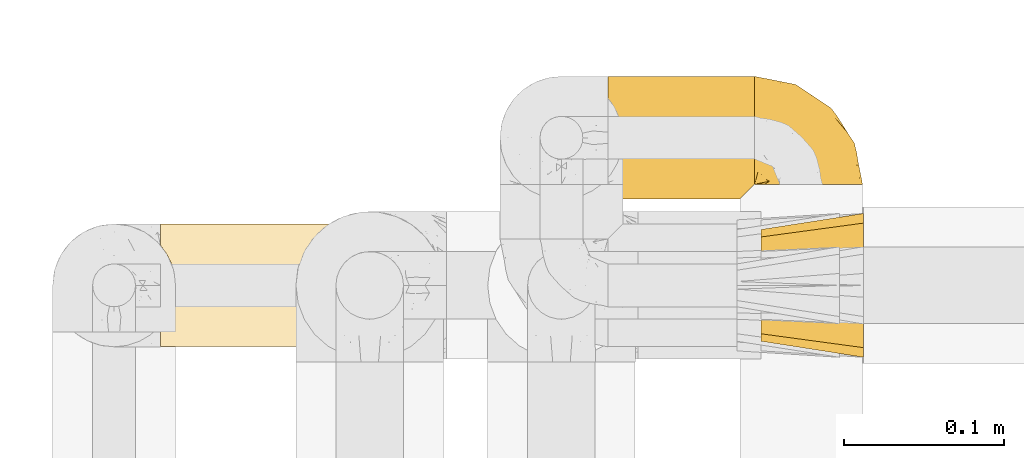
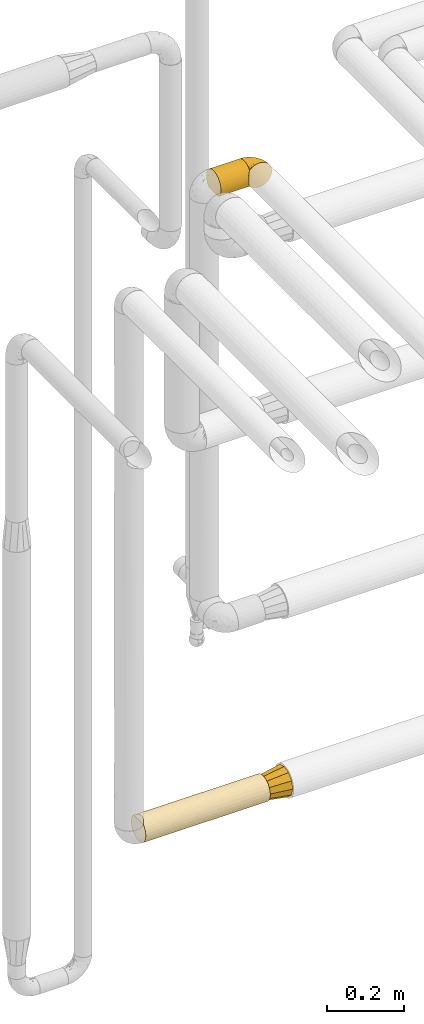
# One storey, part 432 of 827: 4 coverings.
"""IFC2X3 building model written with IfcOpenShell, lengths in millimetres."""

from ifc_helpers import new_model, entity, si_unit, converted_unit, derived_unit, direction, frame, origin, place, context, subcontext, project, spatial, faceted_brep, element, save


model = new_model("IFC2X3")

# Units and contexts
model_context = context("Model", 3, precision=0.01, world=origin(), true_north=direction((6.12303176911189e-17, 1.0)))
body_context = subcontext(model_context, "Body", "Model", "MODEL_VIEW")
ifc_project = project(units=[si_unit("LENGTHUNIT", "METRE", prefix="MILLI"), si_unit("AREAUNIT", "SQUARE_METRE"), si_unit("VOLUMEUNIT", "CUBIC_METRE"), converted_unit("PLANEANGLEUNIT", "DEGREE", entity("IfcRatioMeasure", 0.0174532925199433), si_unit("PLANEANGLEUNIT", "RADIAN"), dimensions=[0, 0, 0, 0, 0, 0, 0]), si_unit("MASSUNIT", "GRAM", prefix="KILO"), derived_unit("MASSDENSITYUNIT", [(si_unit("MASSUNIT", "GRAM", prefix="KILO"), 1), (si_unit("LENGTHUNIT", "METRE"), -3)]), derived_unit("MOMENTOFINERTIAUNIT", [(si_unit("LENGTHUNIT", "METRE"), 4)]), si_unit("TIMEUNIT", "SECOND"), si_unit("FREQUENCYUNIT", "HERTZ"), si_unit("THERMODYNAMICTEMPERATUREUNIT", "DEGREE_CELSIUS"), derived_unit("THERMALTRANSMITTANCEUNIT", [(si_unit("MASSUNIT", "GRAM", prefix="KILO"), 1), (si_unit("THERMODYNAMICTEMPERATUREUNIT", "KELVIN"), -1), (si_unit("TIMEUNIT", "SECOND"), -3)]), derived_unit("VOLUMETRICFLOWRATEUNIT", [(si_unit("LENGTHUNIT", "METRE"), 3), (si_unit("TIMEUNIT", "SECOND"), -1)]), derived_unit("MASSFLOWRATEUNIT", [(si_unit("MASSUNIT", "GRAM", prefix="KILO"), 1), (si_unit("TIMEUNIT", "SECOND"), -1)]), derived_unit("ROTATIONALFREQUENCYUNIT", [(si_unit("TIMEUNIT", "SECOND"), -1)]), si_unit("ELECTRICCURRENTUNIT", "AMPERE"), si_unit("ELECTRICVOLTAGEUNIT", "VOLT"), si_unit("POWERUNIT", "WATT"), si_unit("FORCEUNIT", "NEWTON", prefix="KILO"), si_unit("ILLUMINANCEUNIT", "LUX"), si_unit("LUMINOUSFLUXUNIT", "LUMEN"), si_unit("LUMINOUSINTENSITYUNIT", "CANDELA"), derived_unit("USERDEFINED", [(si_unit("MASSUNIT", "GRAM", prefix="KILO"), -1), (si_unit("LENGTHUNIT", "METRE"), -2), (si_unit("TIMEUNIT", "SECOND"), 3), (si_unit("LUMINOUSFLUXUNIT", "LUMEN"), 1)]), derived_unit("LINEARVELOCITYUNIT", [(si_unit("LENGTHUNIT", "METRE"), 1), (si_unit("TIMEUNIT", "SECOND"), -1)]), si_unit("PRESSUREUNIT", "PASCAL"), derived_unit("USERDEFINED", [(si_unit("LENGTHUNIT", "METRE"), -2), (si_unit("MASSUNIT", "GRAM", prefix="KILO"), 1), (si_unit("TIMEUNIT", "SECOND"), -2)]), derived_unit("LINEARFORCEUNIT", [(si_unit("MASSUNIT", "GRAM", prefix="KILO"), 1), (si_unit("LENGTHUNIT", "METRE"), 1), (si_unit("TIMEUNIT", "SECOND"), -2), (si_unit("LENGTHUNIT", "METRE"), -1)]), derived_unit("PLANARFORCEUNIT", [(si_unit("MASSUNIT", "GRAM", prefix="KILO"), 1), (si_unit("LENGTHUNIT", "METRE"), 1), (si_unit("TIMEUNIT", "SECOND"), -2), (si_unit("LENGTHUNIT", "METRE"), -2)])], contexts=[model_context])

# Site, building, storey
site_placement = place(None, origin())
site = spatial("IfcSite", under=ifc_project, at=site_placement, CompositionType="ELEMENT")
building_placement = place(site_placement, origin())
building = spatial("IfcBuilding", under=site, at=building_placement, CompositionType="ELEMENT")
storey_placement = place(building_placement, frame((0.0, 0.0, 28200.0)))
storey = spatial("IfcBuildingStorey", under=building, at=storey_placement, Name="08", CompositionType="ELEMENT", Elevation=28200.0)

# Coverings
covering_1_placement = place(storey_placement, frame((53937.29, 17460.0, 752.5)))
element("IfcCovering", 1, at=covering_1_placement, inside=storey, Name=":ADSK_", ObjectType=":ADSK_", PredefinedType="INSULATION", context=body_context, shape_type="Brep", body=[
    faceted_brep([(377.5, 73.25, 20.8), (377.5, 77.09, 30.06), (377.5, 78.4, 40.0), (377.5, 77.09, 49.93), (377.5, 73.25, 59.2), (377.5, 67.15, 67.15), (377.5, 59.2, 73.25), (377.5, 49.93, 77.09), (377.5, 40.0, 78.4), (377.5, 30.06, 77.09), (377.5, 20.8, 73.25), (377.5, 12.84, 67.15), (377.5, 6.74, 59.2), (377.5, 2.9, 49.93), (377.5, 1.6, 40.0), (377.5, 2.9, 30.06), (377.5, 6.74, 20.8), (377.5, 12.84, 12.84), (377.5, 20.8, 6.74), (377.5, 30.06, 2.9), (377.5, 40.0, 1.6), (377.5, 49.93, 2.9), (377.5, 59.2, 6.74), (377.5, 67.15, 12.84), (1.6, 77.09, 30.06), (1.6, 73.25, 20.8), (1.6, 67.15, 12.84), (1.6, 59.2, 6.74), (1.6, 49.93, 2.9), (1.6, 40.0, 1.6), (1.6, 30.06, 2.9), (1.6, 20.8, 6.74), (1.6, 12.84, 12.84), (1.6, 6.74, 20.8), (1.6, 2.9, 30.06), (1.6, 1.6, 40.0), (1.6, 2.48, 48.2), (1.6, 5.09, 56.01), (1.6, 9.31, 63.08), (1.6, 14.94, 69.1), (1.6, 65.05, 69.1), (1.6, 70.68, 63.08), (1.6, 74.9, 56.01), (1.6, 77.51, 48.2), (1.6, 78.4, 40.0), (5.57, 59.51, 73.07), (8.5, 53.36, 76.0), (10.29, 46.78, 77.79), (10.9, 40.0, 78.4), (10.29, 33.21, 77.79), (8.5, 26.63, 76.0), (5.57, 20.48, 73.07)], [[[0, 1, 2, 3, 4, 5, 6, 7, 8, 9, 10, 11, 12, 13, 14, 15, 16, 17, 18, 19, 20, 21, 22, 23]], [[24, 25, 26, 27, 28, 29, 30, 31, 32, 33, 34, 35, 36, 37, 38, 39, 40, 41, 42, 43, 44]], [[34, 33, 16, 15]], [[35, 34, 15, 14]], [[17, 16, 33, 32]], [[19, 18, 31, 30]], [[20, 19, 30, 29]], [[32, 31, 18, 17]], [[21, 20, 29, 28]], [[22, 21, 28, 27]], [[27, 26, 23, 22]], [[1, 0, 25, 24]], [[2, 1, 24, 44]], [[26, 25, 0, 23]], [[2, 44, 43]], [[3, 43, 42]], [[4, 42, 41]], [[2, 43, 3]], [[3, 42, 4]], [[41, 5, 4]], [[41, 40, 5]], [[40, 45, 6]], [[46, 47, 7]], [[45, 46, 6]], [[6, 46, 7]], [[8, 7, 47]], [[48, 8, 47]], [[40, 6, 5]], [[49, 50, 9]], [[51, 39, 10]], [[50, 51, 10]], [[48, 49, 8]], [[8, 49, 9]], [[50, 10, 9]], [[39, 11, 10]], [[12, 38, 37]], [[13, 37, 36]], [[14, 36, 35]], [[11, 38, 12]], [[12, 37, 13]], [[36, 14, 13]], [[38, 11, 39]], [[39, 51, 50, 49, 48, 47, 46, 45, 40]]]),
])
covering_2_placement = place(storey_placement, frame((54314.79, 17453.4, 745.9)))
element("IfcCovering", 2, at=covering_2_placement, inside=storey, Name=":ADSK_", ObjectType=":ADSK_", PredefinedType="INSULATION", context=body_context, shape_type="Brep", body=[
    faceted_brep([(64.0, 15.86, 77.33), (64.0, 7.62, 69.1), (64.0, 5.02, 59.38), (64.0, 1.6, 46.6), (64.0, 5.02, 33.81), (64.0, 7.62, 24.1), (64.0, 15.86, 15.86), (64.0, 24.1, 7.62), (64.0, 33.81, 5.02), (64.0, 46.6, 1.6), (64.0, 59.38, 5.02), (64.0, 69.1, 7.62), (64.0, 77.33, 15.86), (64.0, 85.57, 24.1), (64.0, 88.17, 33.81), (64.0, 91.6, 46.6), (64.0, 88.17, 59.38), (64.0, 85.57, 69.1), (64.0, 77.33, 77.33), (64.0, 69.1, 85.57), (64.0, 59.38, 88.17), (64.0, 46.6, 91.6), (64.0, 33.81, 88.17), (64.0, 24.1, 85.57), (0.0, 64.1, 76.91), (0.0, 70.5, 70.5), (0.0, 76.91, 64.1), (0.0, 79.25, 55.35), (0.0, 81.6, 46.6), (0.0, 79.25, 37.85), (0.0, 76.91, 29.1), (0.0, 70.5, 22.69), (0.0, 64.1, 16.28), (0.0, 55.35, 13.94), (0.0, 46.6, 11.6), (0.0, 37.85, 13.94), (0.0, 29.1, 16.28), (0.0, 22.69, 22.69), (0.0, 16.28, 29.1), (0.0, 13.94, 37.85), (0.0, 11.6, 46.6), (0.0, 13.94, 55.35), (0.0, 16.28, 64.1), (0.0, 22.69, 70.5), (0.0, 29.1, 76.91), (0.0, 37.85, 79.25), (0.0, 46.6, 81.6), (0.0, 55.35, 79.25)], [[[0, 1, 2, 3, 4, 5, 6, 7, 8, 9, 10, 11, 12, 13, 14, 15, 16, 17, 18, 19, 20, 21, 22, 23]], [[24, 25, 26, 27, 28, 29, 30, 31, 32, 33, 34, 35, 36, 37, 38, 39, 40, 41, 42, 43, 44, 45, 46, 47]], [[38, 5, 4, 3, 40, 39]], [[6, 5, 38, 37, 36, 7]], [[35, 34, 9, 8, 7, 36]], [[32, 11, 10, 9, 34, 33]], [[12, 11, 32, 31, 30, 13]], [[29, 28, 15, 14, 13, 30]], [[26, 17, 16, 15, 28, 27]], [[18, 17, 26, 25, 24, 19]], [[47, 46, 21, 20, 19, 24]], [[44, 23, 22, 21, 46, 45]], [[0, 23, 44, 43, 42, 1]], [[41, 40, 3, 2, 1, 42]]]),
])
covering_3_placement = place(storey_placement, frame((54217.29, 17552.38, 2660.0)))
element("IfcCovering", 3, at=covering_3_placement, inside=storey, Name=":ADSK_", ObjectType=":ADSK_", PredefinedType="INSULATION", context=body_context, shape_type="Brep", body=[
    faceted_brep([(93.4, 59.2, 6.74), (93.4, 67.15, 12.84), (93.4, 73.25, 20.8), (93.4, 77.09, 30.06), (93.4, 78.4, 40.0), (93.4, 77.09, 49.93), (93.4, 73.25, 59.2), (93.4, 67.15, 67.15), (93.4, 59.2, 73.25), (93.4, 49.93, 77.09), (93.4, 40.0, 78.4), (93.4, 31.8, 77.51), (93.4, 23.99, 74.9), (93.4, 16.92, 70.69), (93.4, 10.91, 65.07), (93.4, 10.88, 14.96), (93.4, 16.89, 9.32), (93.4, 23.97, 5.1), (93.4, 31.79, 2.48), (93.4, 40.0, 1.6), (93.4, 49.93, 2.9), (1.6, 78.4, 40.0), (1.6, 77.51, 31.79), (1.6, 74.9, 23.98), (1.6, 70.68, 16.91), (1.6, 65.05, 10.9), (1.6, 14.94, 10.9), (1.6, 9.31, 16.91), (1.6, 5.09, 23.98), (1.6, 2.48, 31.79), (1.6, 1.6, 40.0), (1.6, 2.9, 49.93), (1.6, 6.74, 59.2), (1.6, 12.84, 67.15), (1.6, 20.8, 73.25), (1.6, 30.06, 77.09), (1.6, 40.0, 78.4), (1.6, 49.93, 77.09), (1.6, 59.2, 73.25), (1.6, 67.15, 67.15), (1.6, 73.25, 59.2), (1.6, 77.09, 49.93), (84.7, 2.2, 33.21), (89.43, 6.91, 20.5), (86.5, 3.99, 26.64), (84.1, 1.6, 40.0), (5.57, 20.48, 6.92), (8.5, 26.63, 4.0), (10.29, 33.21, 2.2), (10.9, 40.0, 1.6), (10.29, 46.78, 2.2), (8.5, 53.36, 4.0), (5.57, 59.51, 6.92), (86.49, 4.0, 53.37), (84.7, 2.2, 46.79), (89.42, 6.93, 59.53)], [[[0, 1, 2, 3, 4, 5, 6, 7, 8, 9, 10, 11, 12, 13, 14, 15, 16, 17, 18, 19, 20]], [[21, 22, 23, 24, 25, 26, 27, 28, 29, 30, 31, 32, 33, 34, 35, 36, 37, 38, 39, 40, 41]], [[30, 29, 42]], [[28, 27, 43]], [[29, 28, 44]], [[42, 45, 30]], [[43, 44, 28]], [[15, 43, 27]], [[42, 29, 44]], [[27, 26, 15]], [[26, 46, 16]], [[47, 48, 18]], [[46, 47, 17]], [[16, 46, 17]], [[48, 19, 18]], [[18, 17, 47]], [[19, 48, 49]], [[26, 16, 15]], [[50, 51, 20]], [[52, 25, 0]], [[51, 52, 0]], [[49, 50, 19]], [[19, 50, 20]], [[51, 0, 20]], [[25, 1, 0]], [[2, 24, 23]], [[3, 23, 22]], [[4, 22, 21]], [[1, 24, 2]], [[2, 23, 3]], [[22, 4, 3]], [[24, 1, 25]], [[5, 4, 21, 41]], [[6, 5, 41, 40]], [[40, 39, 7, 6]], [[9, 8, 38, 37]], [[10, 9, 37, 36]], [[39, 38, 8, 7]], [[11, 36, 35]], [[12, 35, 34]], [[13, 34, 33]], [[10, 36, 11]], [[11, 35, 12]], [[34, 13, 12]], [[33, 14, 13]], [[53, 32, 31]], [[31, 30, 54]], [[45, 54, 30]], [[55, 14, 32]], [[54, 53, 31]], [[55, 32, 53]], [[32, 14, 33]], [[45, 42, 44, 43, 15, 14, 55, 53, 54]], [[25, 52, 51, 50, 49, 48, 47, 46, 26]]]),
])
covering_4_placement = place(storey_placement, frame((54309.09, 17561.68, 2659.95)))
element("IfcCovering", 4, at=covering_4_placement, inside=storey, Name=":ADSK_", ObjectType=":ADSK_", PredefinedType="INSULATION", context=body_context, shape_type="Brep", body=[
    faceted_brep([(1.6, 47.38, 74.68), (1.6, 54.67, 70.1), (1.6, 60.76, 64.01), (1.6, 65.34, 56.72), (1.6, 68.18, 48.6), (1.6, 69.15, 40.05), (1.6, 68.18, 31.49), (1.6, 65.33, 23.36), (1.6, 60.75, 16.07), (1.6, 54.66, 9.98), (1.6, 47.37, 5.4), (1.6, 39.25, 2.56), (1.6, 30.7, 1.6), (1.6, 22.59, 2.46), (1.6, 14.86, 5.01), (1.6, 7.84, 9.13), (1.6, 1.85, 14.62), (1.6, 1.85, 16.82), (1.6, 1.85, 18.56), (1.6, 1.85, 20.52), (1.6, 1.85, 22.49), (1.6, 1.85, 24.46), (1.6, 1.85, 26.42), (1.6, 1.85, 28.39), (1.6, 1.85, 30.36), (1.6, 1.85, 32.55), (1.6, 1.85, 34.75), (1.6, 1.85, 36.94), (1.6, 1.85, 39.13), (1.6, 1.85, 41.33), (1.6, 1.85, 43.52), (1.6, 1.85, 45.72), (1.6, 1.85, 47.91), (1.6, 1.85, 50.11), (1.6, 1.85, 52.3), (1.6, 1.85, 54.49), (1.6, 1.85, 56.69), (1.6, 1.85, 58.88), (1.6, 1.85, 61.08), (1.6, 1.85, 63.27), (1.6, 1.85, 65.47), (1.6, 7.85, 70.97), (1.6, 14.88, 75.09), (1.6, 22.61, 77.64), (1.6, 30.7, 78.5), (1.6, 39.26, 77.53), (1.85, 1.6, 14.62), (7.85, 1.6, 9.12), (14.87, 1.6, 5.0), (22.6, 1.6, 2.46), (30.7, 1.6, 1.6), (40.65, 1.6, 2.91), (49.92, 1.6, 6.75), (57.88, 1.6, 12.86), (63.99, 1.6, 20.82), (67.84, 1.6, 30.09), (69.15, 1.6, 40.05), (67.84, 1.6, 50.0), (63.99, 1.6, 59.27), (57.88, 1.6, 67.23), (49.92, 1.6, 73.34), (40.65, 1.6, 77.19), (30.7, 1.6, 78.5), (22.6, 1.6, 77.63), (14.87, 1.6, 75.09), (7.85, 1.6, 70.97), (1.85, 1.6, 65.47), (1.85, 1.6, 63.27), (1.85, 1.6, 62.29), (1.85, 1.6, 60.7), (1.85, 1.6, 59.11), (1.85, 1.6, 57.52), (1.85, 1.6, 55.93), (1.85, 1.6, 54.34), (1.85, 1.6, 52.76), (1.85, 1.6, 51.17), (1.85, 1.6, 49.58), (1.85, 1.6, 47.99), (1.85, 1.6, 46.4), (1.85, 1.6, 44.81), (1.85, 1.6, 43.22), (1.85, 1.6, 41.63), (1.85, 1.6, 40.05), (1.85, 1.6, 38.46), (1.85, 1.6, 36.87), (1.85, 1.6, 35.28), (1.85, 1.6, 33.69), (1.85, 1.6, 32.1), (1.85, 1.6, 30.51), (1.85, 1.6, 28.92), (1.85, 1.6, 27.33), (1.85, 1.6, 25.37), (1.85, 1.6, 23.4), (1.85, 1.6, 21.21), (1.85, 1.6, 19.01), (1.85, 1.6, 16.82), (1.77, 1.78, 42.32), (1.78, 1.77, 44.02), (1.77, 1.78, 47.13), (1.77, 1.77, 48.74), (1.76, 1.79, 23.57), (1.77, 1.78, 25.13), (1.79, 1.76, 61.34), (1.78, 1.77, 22.02), (1.78, 1.77, 29.72), (1.78, 1.76, 56.73), (1.78, 1.77, 55.14), (1.78, 1.77, 37.66), (1.74, 1.8, 64.12), (1.78, 1.76, 28.13), (1.78, 1.77, 26.62), (1.77, 1.78, 31.46), (1.78, 1.77, 16.16), (1.78, 1.77, 39.16), (1.78, 1.76, 50.37), (1.77, 1.77, 17.69), (1.77, 1.78, 19.17), (1.77, 1.77, 62.78), (1.78, 1.77, 58.35), (1.78, 1.77, 45.53), (1.77, 1.78, 59.91), (1.77, 1.77, 65.47), (1.72, 1.8, 65.47), (1.66, 1.82, 65.47), (1.77, 1.77, 14.62), (1.8, 1.72, 14.62), (1.82, 1.66, 14.62), (1.79, 1.76, 20.59), (1.78, 1.77, 32.99), (1.79, 1.76, 34.48), (1.78, 1.77, 51.91), (1.82, 1.66, 65.47), (1.8, 1.72, 65.47), (1.76, 1.78, 53.48), (1.66, 1.82, 14.62), (1.72, 1.8, 14.62), (1.78, 1.77, 40.77), (1.77, 1.78, 35.97), (9.41, 3.72, 7.84), (17.65, 7.41, 3.53), (7.41, 6.13, 8.32), (15.21, 19.34, 2.19), (7.41, 17.64, 3.53), (16.15, 26.8, 1.6), (28.75, 8.87, 1.6), (13.67, 9.2, 4.57), (12.79, 12.79, 3.96), (19.18, 14.62, 2.28), (29.16, 7.34, 1.6), (9.04, 5.33, 7.69), (5.74, 7.7, 8.32), (3.72, 9.41, 7.84), (8.87, 28.75, 1.6), (21.47, 21.47, 1.6), (26.8, 16.15, 1.6), (9.53, 14.14, 4.34), (7.34, 29.16, 1.6), (37.63, 57.02, 29.63), (17.92, 64.92, 27.34), (27.45, 64.0, 40.05), (37.01, 11.92, 2.39), (34.22, 19.16, 2.43), (45.87, 28.65, 9.07), (56.57, 24.62, 16.64), (52.31, 15.19, 9.54), (42.07, 18.36, 4.52), (44.74, 9.2, 4.52), (21.49, 46.98, 7.49), (11.02, 50.24, 7.49), (15.64, 56.1, 12.85), (26.02, 28.97, 2.35), (36.59, 54.46, 22.66), (65.49, 21.34, 32.9), (63.99, 18.4, 25.33), (15.2, 66.44, 40.05), (60.27, 12.07, 16.64), (45.25, 45.49, 19.99), (35.21, 50.57, 16.37), (22.52, 36.04, 3.26), (12.03, 42.07, 3.75), (13.32, 62.12, 19.58), (35.9, 37.37, 7.5), (33.87, 29.39, 4.04), (25.73, 53.59, 13.94), (26.34, 58.06, 19.58), (46.78, 49.27, 28.21), (59.54, 29.63, 24.75), (60.18, 33.21, 31.42), (53.93, 40.1, 26.2), (53.36, 44.08, 33.36), (49.36, 49.36, 40.05), (38.4, 56.68, 40.05), (66.44, 15.2, 40.05), (50.09, 35.57, 16.14), (41.08, 41.7, 12.85), (31.14, 46.4, 10.47), (28.19, 41.41, 6.49), (64.0, 27.45, 40.05), (56.68, 38.4, 40.05), (43.9, 12.99, 75.57), (65.46, 21.33, 47.37), (52.22, 42.89, 52.91), (37.61, 57.04, 50.46), (15.64, 56.11, 67.23), (13.31, 62.13, 60.5), (50.02, 21.89, 70.55), (59.28, 16.62, 63.45), (53.05, 32.9, 62.61), (21.48, 46.99, 72.6), (11.01, 50.25, 72.6), (12.03, 42.08, 76.34), (41.02, 49.91, 59.34), (35.39, 15.6, 77.76), (26.8, 16.15, 78.5), (28.75, 8.87, 78.5), (7.34, 29.16, 78.5), (65.81, 13.16, 53.16), (53.28, 10.83, 70.55), (59.8, 33.8, 48.88), (61.82, 25.02, 54.76), (17.91, 64.92, 52.74), (41.4, 32.83, 71.93), (40.48, 20.56, 75.79), (26.34, 58.07, 60.5), (31.68, 21.46, 77.86), (27.68, 28.1, 77.64), (16.15, 26.8, 78.5), (21.47, 21.47, 78.5), (28.05, 51.29, 67.23), (22.54, 36.04, 76.82), (8.87, 28.75, 78.5), (37.3, 8.45, 77.8), (41.07, 41.73, 67.23), (32.24, 39.27, 73.2), (47.4, 33.56, 67.66), (35.77, 27.29, 75.99), (17.65, 7.41, 76.57), (11.06, 3.51, 73.21), (8.55, 4.68, 71.93), (6.63, 5.52, 71.07), (12.77, 8.75, 75.09), (12.79, 12.79, 76.13), (7.41, 17.65, 76.57), (18.97, 13.9, 77.69), (3.72, 9.42, 72.26), (5.76, 7.68, 71.77), (15.21, 19.33, 77.9), (9.52, 14.13, 75.75)], [[[0, 1, 2, 3, 4, 5, 6, 7, 8, 9, 10, 11, 12, 13, 14, 15, 16, 17, 18, 19, 20, 21, 22, 23, 24, 25, 26, 27, 28, 29, 30, 31, 32, 33, 34, 35, 36, 37, 38, 39, 40, 41, 42, 43, 44, 45]], [[46, 47, 48, 49, 50, 51, 52, 53, 54, 55, 56, 57, 58, 59, 60, 61, 62, 63, 64, 65, 66, 67, 68, 69, 70, 71, 72, 73, 74, 75, 76, 77, 78, 79, 80, 81, 82, 83, 84, 85, 86, 87, 88, 89, 90, 91, 92, 93, 94, 95]], [[96, 97, 30]], [[98, 77, 99]], [[100, 101, 21]], [[69, 68, 102]], [[20, 19, 103]], [[24, 23, 104]], [[20, 103, 100]], [[72, 105, 106]], [[84, 83, 107]], [[89, 88, 104]], [[108, 67, 66]], [[109, 110, 90]], [[111, 25, 24]], [[112, 17, 16]], [[82, 113, 83]], [[109, 23, 22]], [[114, 76, 75]], [[105, 36, 106]], [[104, 111, 24]], [[18, 115, 116]], [[97, 96, 80]], [[67, 108, 117]], [[105, 71, 118]], [[31, 97, 119]], [[102, 120, 69]], [[108, 121, 122, 123, 40]], [[112, 95, 115]], [[17, 115, 18]], [[94, 116, 115]], [[117, 68, 67]], [[38, 117, 39]], [[112, 124, 125, 126, 46]], [[17, 112, 115]], [[70, 120, 118]], [[39, 117, 108]], [[120, 38, 37]], [[120, 37, 118]], [[120, 70, 69]], [[116, 94, 127]], [[128, 86, 129]], [[117, 38, 102]], [[74, 130, 75]], [[99, 33, 32]], [[115, 95, 94]], [[39, 108, 40]], [[108, 66, 131, 132, 121]], [[105, 72, 71]], [[118, 37, 36]], [[71, 70, 118]], [[35, 106, 36]], [[36, 105, 118]], [[35, 133, 106]], [[74, 73, 133]], [[106, 133, 73]], [[99, 114, 33]], [[133, 35, 34]], [[73, 72, 106]], [[95, 112, 46]], [[112, 16, 134, 135, 124]], [[130, 114, 75]], [[99, 76, 114]], [[114, 130, 33]], [[34, 33, 130]], [[78, 77, 98]], [[98, 119, 78]], [[130, 133, 34]], [[133, 130, 74]], [[79, 97, 80]], [[98, 99, 32]], [[98, 32, 31]], [[77, 76, 99]], [[97, 79, 119]], [[136, 96, 29]], [[30, 97, 31]], [[136, 29, 28]], [[81, 80, 96]], [[29, 96, 30]], [[31, 119, 98]], [[119, 79, 78]], [[96, 136, 81]], [[82, 81, 136]], [[113, 107, 83]], [[84, 107, 137]], [[107, 27, 137]], [[113, 28, 107]], [[27, 107, 28]], [[85, 84, 137]], [[137, 27, 26]], [[113, 136, 28]], [[136, 113, 82]], [[109, 89, 104]], [[86, 85, 129]], [[89, 109, 90]], [[111, 87, 128]], [[26, 129, 137]], [[88, 111, 104]], [[25, 111, 128]], [[22, 110, 109]], [[23, 109, 104]], [[110, 91, 90]], [[100, 92, 101]], [[110, 22, 101]], [[91, 110, 101]], [[116, 19, 18]], [[111, 88, 87]], [[127, 103, 19]], [[25, 128, 26]], [[86, 128, 87]], [[128, 129, 26]], [[137, 129, 85]], [[120, 102, 38]], [[117, 102, 68]], [[91, 101, 92]], [[21, 101, 22]], [[93, 92, 103]], [[100, 21, 20]], [[100, 103, 92]], [[127, 93, 103]], [[93, 127, 94]], [[116, 127, 19]], [[126, 138, 47]], [[48, 138, 139]], [[140, 125, 124]], [[141, 142, 143]], [[144, 49, 139]], [[145, 140, 146]], [[48, 139, 49]], [[139, 145, 147]], [[49, 144, 148, 50]], [[126, 125, 149]], [[14, 13, 142]], [[150, 146, 140]], [[149, 140, 145]], [[151, 150, 135]], [[151, 14, 142]], [[16, 15, 134]], [[13, 152, 142]], [[124, 150, 140]], [[141, 143, 153]], [[14, 151, 15]], [[15, 151, 134]], [[47, 46, 126]], [[139, 154, 144]], [[138, 48, 47]], [[125, 140, 149]], [[135, 134, 151]], [[146, 155, 141]], [[145, 146, 147]], [[149, 139, 138]], [[147, 153, 154]], [[147, 146, 141]], [[139, 147, 154]], [[139, 149, 145]], [[149, 138, 126]], [[147, 141, 153]], [[146, 150, 155]], [[151, 155, 150]], [[142, 141, 155]], [[13, 12, 156, 152]], [[152, 143, 142]], [[151, 142, 155]], [[150, 124, 135]], [[157, 158, 159]], [[160, 154, 161]], [[162, 163, 164]], [[165, 166, 160]], [[167, 168, 169]], [[153, 170, 161]], [[156, 12, 11]], [[158, 157, 171]], [[172, 55, 173]], [[158, 6, 174]], [[175, 54, 53]], [[52, 166, 164]], [[52, 164, 53]], [[54, 175, 173]], [[166, 52, 51]], [[176, 177, 171]], [[178, 143, 179]], [[156, 11, 179]], [[8, 7, 180]], [[169, 9, 8]], [[179, 143, 152, 156]], [[179, 11, 10]], [[168, 179, 10]], [[181, 162, 182]], [[179, 167, 178]], [[183, 184, 177]], [[183, 169, 184]], [[176, 171, 185]], [[172, 186, 187]], [[158, 7, 6]], [[159, 158, 174]], [[184, 180, 158]], [[54, 173, 55]], [[180, 169, 8]], [[188, 189, 187]], [[9, 168, 10]], [[186, 188, 187]], [[190, 157, 159, 191]], [[55, 172, 192]], [[176, 193, 194]], [[161, 170, 182]], [[162, 164, 165]], [[175, 164, 163]], [[51, 50, 148]], [[167, 195, 196]], [[178, 182, 170]], [[6, 5, 174]], [[158, 180, 7]], [[169, 180, 184]], [[169, 168, 9]], [[179, 168, 167]], [[182, 162, 165]], [[162, 194, 193]], [[161, 165, 160]], [[195, 181, 196]], [[192, 172, 197]], [[192, 56, 55]], [[189, 190, 198]], [[198, 197, 187]], [[172, 187, 197]], [[185, 189, 188]], [[198, 187, 189]], [[186, 172, 173]], [[173, 163, 186]], [[193, 186, 163]], [[176, 185, 188]], [[185, 157, 190]], [[188, 186, 193]], [[177, 176, 194]], [[188, 193, 176]], [[162, 193, 163]], [[195, 177, 194]], [[171, 177, 184]], [[181, 195, 194]], [[183, 167, 169]], [[162, 181, 194]], [[196, 182, 178]], [[158, 171, 184]], [[171, 157, 185]], [[177, 195, 183]], [[167, 183, 195]], [[182, 196, 181]], [[178, 170, 143]], [[178, 167, 196]], [[164, 175, 53]], [[173, 175, 163]], [[160, 51, 148]], [[164, 166, 165]], [[51, 160, 166]], [[160, 148, 144, 154]], [[153, 161, 154]], [[182, 165, 161]], [[190, 189, 185]], [[143, 170, 153]], [[60, 199, 61]], [[197, 200, 192]], [[201, 190, 202]], [[200, 57, 192]], [[203, 204, 2]], [[205, 206, 207]], [[208, 209, 210]], [[211, 207, 201]], [[212, 213, 214]], [[45, 215, 210]], [[216, 206, 58]], [[45, 44, 215]], [[59, 217, 60]], [[60, 217, 199]], [[0, 45, 210]], [[218, 201, 219]], [[202, 159, 220]], [[205, 221, 222]], [[223, 204, 203]], [[1, 203, 2]], [[57, 200, 216]], [[220, 3, 204]], [[220, 174, 4]], [[1, 0, 209]], [[212, 224, 213]], [[225, 226, 227]], [[228, 223, 203]], [[208, 210, 229]], [[210, 226, 229]], [[3, 220, 4]], [[58, 206, 59]], [[209, 203, 1]], [[202, 220, 223]], [[228, 203, 208]], [[202, 211, 201]], [[3, 2, 204]], [[202, 190, 191, 159]], [[210, 215, 230, 226]], [[199, 212, 231]], [[232, 233, 221]], [[233, 208, 229]], [[207, 206, 219]], [[217, 206, 205]], [[227, 224, 225]], [[233, 232, 228]], [[201, 207, 219]], [[234, 232, 221]], [[218, 219, 200]], [[202, 223, 211]], [[174, 220, 159]], [[174, 5, 4]], [[61, 231, 62]], [[220, 204, 223]], [[210, 209, 0]], [[203, 209, 208]], [[225, 233, 229]], [[224, 227, 213]], [[221, 233, 235]], [[57, 56, 192]], [[198, 218, 197]], [[200, 219, 216]], [[201, 198, 190]], [[197, 218, 200]], [[198, 201, 218]], [[206, 216, 219]], [[58, 57, 216]], [[231, 212, 214]], [[222, 212, 199]], [[228, 211, 223]], [[207, 211, 232]], [[62, 231, 214]], [[199, 231, 61]], [[233, 228, 208]], [[211, 228, 232]], [[222, 221, 235]], [[234, 205, 207]], [[206, 217, 59]], [[199, 217, 205]], [[205, 222, 199]], [[224, 222, 235]], [[222, 224, 212]], [[224, 235, 225]], [[233, 225, 235]], [[226, 225, 229]], [[205, 234, 221]], [[207, 232, 234]], [[63, 214, 236]], [[214, 213, 236]], [[214, 63, 62]], [[237, 236, 238]], [[238, 132, 131]], [[236, 237, 64]], [[239, 240, 241]], [[63, 236, 64]], [[131, 66, 65]], [[237, 131, 65]], [[242, 230, 43]], [[237, 65, 64]], [[239, 121, 132]], [[42, 242, 43]], [[241, 240, 243]], [[41, 123, 244]], [[43, 230, 215, 44]], [[244, 122, 245]], [[227, 246, 243]], [[241, 243, 246]], [[121, 239, 245]], [[41, 40, 123]], [[132, 238, 239]], [[244, 42, 41]], [[131, 237, 238]], [[240, 239, 238]], [[245, 239, 241]], [[247, 241, 246]], [[247, 244, 245]], [[238, 236, 240]], [[243, 236, 213]], [[236, 243, 240]], [[226, 246, 227]], [[243, 213, 227]], [[226, 242, 246]], [[241, 247, 245]], [[246, 242, 247]], [[244, 247, 242]], [[242, 226, 230]], [[42, 244, 242]], [[122, 244, 123]], [[122, 121, 245]]]),
])

save(model, "model.ifc")
